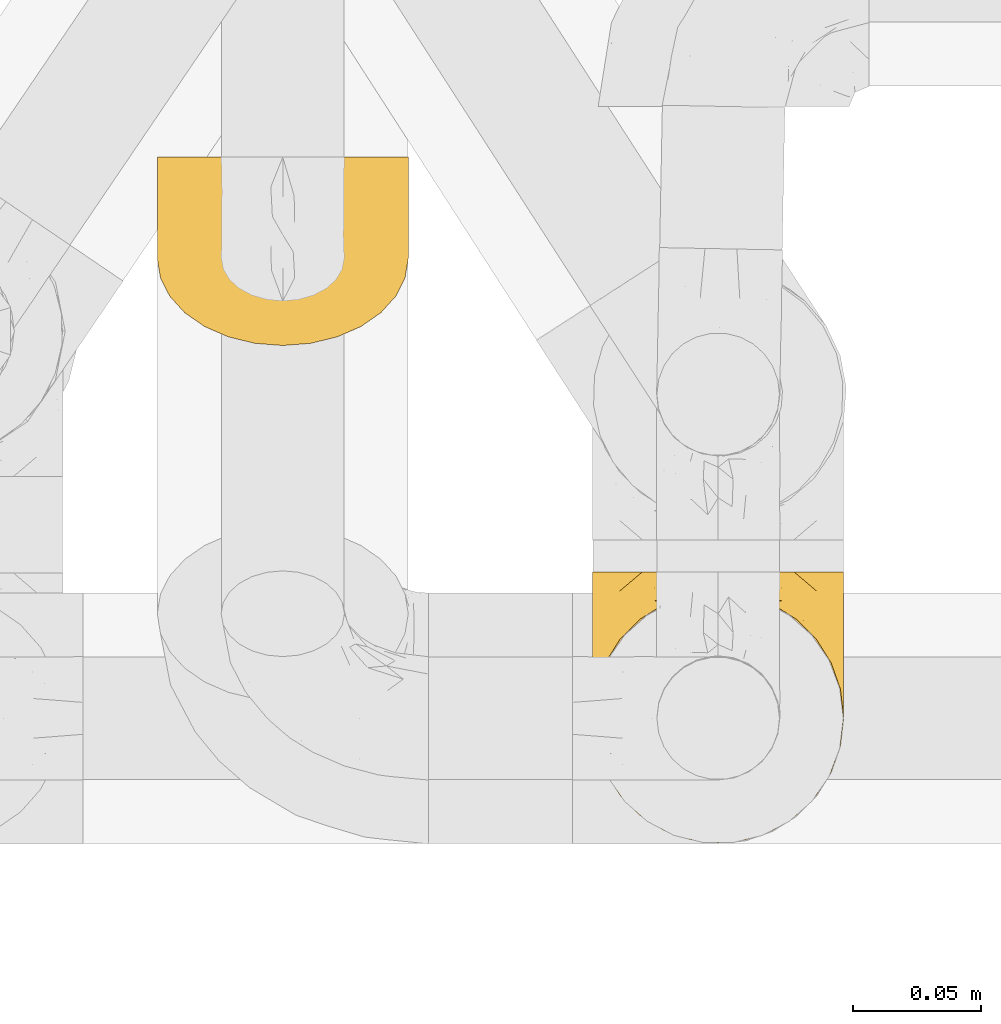
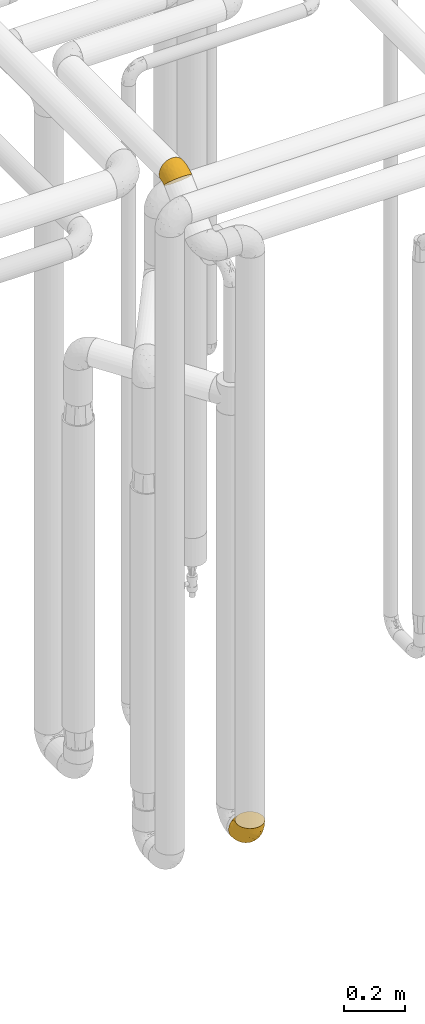
# One storey, part 386 of 827: 2 coverings.
"""IFC2X3 building model written with IfcOpenShell, lengths in millimetres."""

from ifc_helpers import new_model, entity, si_unit, converted_unit, derived_unit, direction, frame, origin, place, context, subcontext, project, spatial, faceted_brep, element, save


model = new_model("IFC2X3")

# Units and contexts
model_context = context("Model", 3, precision=0.01, world=origin(), true_north=direction((6.12303176911189e-17, 1.0)))
body_context = subcontext(model_context, "Body", "Model", "MODEL_VIEW")
ifc_project = project(units=[si_unit("LENGTHUNIT", "METRE", prefix="MILLI"), si_unit("AREAUNIT", "SQUARE_METRE"), si_unit("VOLUMEUNIT", "CUBIC_METRE"), converted_unit("PLANEANGLEUNIT", "DEGREE", entity("IfcRatioMeasure", 0.0174532925199433), si_unit("PLANEANGLEUNIT", "RADIAN"), dimensions=[0, 0, 0, 0, 0, 0, 0]), si_unit("MASSUNIT", "GRAM", prefix="KILO"), derived_unit("MASSDENSITYUNIT", [(si_unit("MASSUNIT", "GRAM", prefix="KILO"), 1), (si_unit("LENGTHUNIT", "METRE"), -3)]), derived_unit("MOMENTOFINERTIAUNIT", [(si_unit("LENGTHUNIT", "METRE"), 4)]), si_unit("TIMEUNIT", "SECOND"), si_unit("FREQUENCYUNIT", "HERTZ"), si_unit("THERMODYNAMICTEMPERATUREUNIT", "DEGREE_CELSIUS"), derived_unit("THERMALTRANSMITTANCEUNIT", [(si_unit("MASSUNIT", "GRAM", prefix="KILO"), 1), (si_unit("THERMODYNAMICTEMPERATUREUNIT", "KELVIN"), -1), (si_unit("TIMEUNIT", "SECOND"), -3)]), derived_unit("VOLUMETRICFLOWRATEUNIT", [(si_unit("LENGTHUNIT", "METRE"), 3), (si_unit("TIMEUNIT", "SECOND"), -1)]), derived_unit("MASSFLOWRATEUNIT", [(si_unit("MASSUNIT", "GRAM", prefix="KILO"), 1), (si_unit("TIMEUNIT", "SECOND"), -1)]), derived_unit("ROTATIONALFREQUENCYUNIT", [(si_unit("TIMEUNIT", "SECOND"), -1)]), si_unit("ELECTRICCURRENTUNIT", "AMPERE"), si_unit("ELECTRICVOLTAGEUNIT", "VOLT"), si_unit("POWERUNIT", "WATT"), si_unit("FORCEUNIT", "NEWTON", prefix="KILO"), si_unit("ILLUMINANCEUNIT", "LUX"), si_unit("LUMINOUSFLUXUNIT", "LUMEN"), si_unit("LUMINOUSINTENSITYUNIT", "CANDELA"), derived_unit("USERDEFINED", [(si_unit("MASSUNIT", "GRAM", prefix="KILO"), -1), (si_unit("LENGTHUNIT", "METRE"), -2), (si_unit("TIMEUNIT", "SECOND"), 3), (si_unit("LUMINOUSFLUXUNIT", "LUMEN"), 1)]), derived_unit("LINEARVELOCITYUNIT", [(si_unit("LENGTHUNIT", "METRE"), 1), (si_unit("TIMEUNIT", "SECOND"), -1)]), si_unit("PRESSUREUNIT", "PASCAL"), derived_unit("USERDEFINED", [(si_unit("LENGTHUNIT", "METRE"), -2), (si_unit("MASSUNIT", "GRAM", prefix="KILO"), 1), (si_unit("TIMEUNIT", "SECOND"), -2)]), derived_unit("LINEARFORCEUNIT", [(si_unit("MASSUNIT", "GRAM", prefix="KILO"), 1), (si_unit("LENGTHUNIT", "METRE"), 1), (si_unit("TIMEUNIT", "SECOND"), -2), (si_unit("LENGTHUNIT", "METRE"), -1)]), derived_unit("PLANARFORCEUNIT", [(si_unit("MASSUNIT", "GRAM", prefix="KILO"), 1), (si_unit("LENGTHUNIT", "METRE"), 1), (si_unit("TIMEUNIT", "SECOND"), -2), (si_unit("LENGTHUNIT", "METRE"), -2)])], contexts=[model_context])

# Site, building, storey
site_placement = place(None, origin())
site = spatial("IfcSite", under=ifc_project, at=site_placement, CompositionType="ELEMENT")
building_placement = place(site_placement, origin())
building = spatial("IfcBuilding", under=site, at=building_placement, CompositionType="ELEMENT")
storey_placement = place(building_placement, frame((0.0, 0.0, 28200.0)))
storey = spatial("IfcBuildingStorey", under=building, at=storey_placement, Name="08", CompositionType="ELEMENT", Elevation=28200.0)

# Coverings
covering_1_placement = place(storey_placement, frame((46777.25, 13781.27, 2947.05)))
element("IfcCovering", 1, at=covering_1_placement, inside=storey, Name=":ADSK_", ObjectType=":ADSK_", PredefinedType="INSULATION", context=body_context, shape_type="Brep", body=[
    faceted_brep([(61.69, 69.06, 2.48), (72.08, 66.53, 5.1), (81.4, 62.46, 9.31), (89.18, 57.05, 14.91), (95.03, 50.57, 21.61), (98.66, 43.35, 29.07), (99.9, 35.76, 36.93), (98.66, 28.15, 44.8), (95.02, 20.93, 52.27), (89.17, 14.45, 58.97), (81.38, 9.04, 64.56), (72.06, 4.98, 68.77), (61.68, 2.45, 71.39), (50.75, 1.6, 72.27), (39.8, 2.45, 71.38), (29.41, 4.98, 68.77), (20.09, 9.05, 64.56), (12.31, 14.46, 58.96), (6.46, 20.94, 52.26), (2.83, 28.16, 44.79), (1.6, 35.76, 36.93), (2.83, 43.36, 29.07), (6.47, 50.58, 21.59), (12.32, 57.06, 14.89), (20.11, 62.47, 9.3), (29.43, 66.54, 5.09), (39.81, 69.06, 2.48), (50.75, 69.92, 1.6), (38.02, 75.37, 5.48), (26.17, 75.37, 10.39), (15.99, 75.37, 18.2), (8.18, 75.37, 28.38), (3.27, 75.37, 40.23), (2.78, 75.37, 43.98), (1.6, 75.37, 52.95), (3.27, 75.37, 65.67), (8.18, 75.37, 77.53), (15.99, 75.37, 87.71), (26.17, 75.37, 95.52), (38.02, 75.37, 100.43), (50.75, 75.37, 102.1), (63.47, 75.37, 100.43), (75.32, 75.37, 95.52), (85.5, 75.37, 87.71), (93.31, 75.37, 77.53), (98.22, 75.37, 65.67), (99.9, 75.37, 52.95), (98.71, 75.37, 43.98), (98.22, 75.37, 40.23), (93.31, 75.37, 28.38), (85.5, 75.37, 18.2), (75.32, 75.37, 10.39), (63.47, 75.37, 5.48), (50.75, 75.37, 3.8), (84.47, 27.34, 75.3), (50.75, 48.48, 98.64), (58.96, 58.66, 100.08), (75.19, 37.47, 88.1), (83.8, 46.12, 84.63), (77.3, 56.48, 92.48), (50.75, 23.34, 88.47), (63.54, 43.26, 95.35), (89.33, 59.62, 81.97), (66.19, 21.25, 84.36), (90.84, 42.68, 74.87), (96.4, 39.77, 62.18), (95.33, 57.71, 71.6), (98.75, 55.84, 60.64), (68.68, 60.14, 97.58), (99.31, 42.12, 51.28), (99.9, 54.01, 48.8), (76.11, 20.02, 78.15), (91.7, 27.99, 65.53), (99.9, 40.39, 39.94), (99.9, 45.03, 42.96), (99.9, 49.52, 45.88), (99.9, 59.26, 49.82), (99.9, 64.52, 50.84), (99.9, 67.24, 51.37), (99.9, 69.95, 51.9), (69.49, 70.82, 6.58), (97.8, 60.98, 36.27), (98.04, 67.74, 38.91), (95.99, 59.44, 30.22), (91.8, 63.88, 23.63), (87.17, 69.77, 19.28), (93.12, 69.11, 27.44), (98.68, 47.33, 32.56), (59.8, 72.32, 4.09), (81.32, 68.15, 13.0), (88.57, 61.45, 17.44), (96.07, 55.44, 28.3), (99.05, 55.09, 39.35), (50.75, 72.43, 3.23), (98.98, 51.04, 36.83), (14.32, 69.77, 19.29), (20.19, 68.16, 12.99), (8.37, 69.11, 27.44), (41.7, 72.32, 4.09), (32.02, 70.82, 6.57), (1.6, 40.39, 39.94), (9.71, 63.89, 23.61), (1.6, 64.52, 50.84), (1.6, 69.95, 51.9), (3.45, 67.74, 38.91), (1.6, 49.52, 45.88), (2.51, 50.99, 36.8), (1.6, 45.03, 42.96), (3.69, 60.97, 36.25), (2.82, 47.34, 32.56), (12.94, 61.45, 17.43), (5.43, 55.45, 28.28), (1.6, 54.01, 48.8), (2.44, 55.06, 39.33), (5.52, 59.45, 30.19), (1.6, 59.26, 49.82), (5.08, 39.77, 62.17), (17.01, 27.35, 75.29), (25.37, 20.02, 78.14), (26.29, 37.48, 88.09), (2.74, 55.84, 60.63), (35.29, 21.26, 84.36), (6.15, 57.72, 71.59), (10.64, 42.69, 74.86), (42.53, 58.66, 100.08), (24.18, 56.49, 92.47), (37.94, 43.27, 95.35), (12.15, 59.61, 81.96), (17.68, 46.12, 84.62), (32.8, 60.13, 97.57), (2.18, 42.12, 51.27), (9.78, 28.0, 65.52)], [[[0, 1, 2, 3, 4, 5, 6, 7, 8, 9, 10, 11, 12, 13, 14, 15, 16, 17, 18, 19, 20, 21, 22, 23, 24, 25, 26, 27]], [[28, 29, 30, 31, 32, 33, 34, 35, 36, 37, 38, 39, 40, 41, 42, 43, 44, 45, 46, 47, 48, 49, 50, 51, 52, 53]], [[9, 54, 10]], [[40, 55, 56]], [[57, 58, 59]], [[55, 60, 61]], [[62, 43, 58]], [[63, 57, 61]], [[58, 54, 64]], [[64, 65, 66]], [[67, 46, 45]], [[66, 65, 67]], [[56, 68, 41]], [[67, 69, 70]], [[57, 54, 58]], [[71, 54, 57]], [[63, 61, 60]], [[60, 12, 63]], [[11, 10, 71]], [[11, 71, 63]], [[43, 59, 58]], [[13, 12, 60]], [[72, 54, 9]], [[59, 43, 42]], [[57, 59, 68]], [[69, 6, 73, 74, 75, 70]], [[8, 7, 65]], [[72, 65, 64]], [[63, 71, 57]], [[54, 71, 10]], [[8, 72, 9]], [[56, 55, 61]], [[62, 58, 64]], [[11, 63, 12]], [[42, 41, 68]], [[66, 44, 62]], [[7, 69, 65]], [[45, 44, 66]], [[67, 70, 76, 77, 78, 79, 46]], [[45, 66, 67]], [[66, 62, 64]], [[43, 62, 44]], [[65, 72, 8]], [[54, 72, 64]], [[65, 69, 67]], [[6, 69, 7]], [[61, 57, 68]], [[40, 56, 41]], [[61, 68, 56]], [[42, 68, 59]], [[51, 80, 52]], [[81, 82, 76]], [[83, 84, 81]], [[84, 85, 86]], [[48, 78, 82]], [[85, 51, 50]], [[4, 87, 5]], [[88, 0, 27]], [[89, 1, 80]], [[53, 52, 88]], [[51, 89, 80]], [[86, 50, 49]], [[85, 50, 86]], [[81, 86, 82]], [[90, 91, 3]], [[4, 3, 91]], [[91, 83, 92]], [[6, 5, 73]], [[81, 84, 86]], [[82, 86, 49]], [[48, 47, 46, 79, 78]], [[93, 88, 27]], [[92, 94, 91]], [[1, 0, 80]], [[2, 1, 89]], [[87, 73, 5]], [[0, 88, 80]], [[90, 89, 84]], [[48, 82, 49]], [[2, 90, 3]], [[70, 81, 76]], [[53, 88, 93]], [[89, 90, 2]], [[90, 84, 83]], [[82, 78, 77, 76]], [[84, 89, 85]], [[51, 85, 89]], [[91, 87, 4]], [[73, 87, 74]], [[81, 92, 83]], [[87, 94, 74]], [[80, 88, 52]], [[81, 70, 92]], [[90, 83, 91]], [[70, 75, 92]], [[92, 75, 94]], [[74, 94, 75]], [[87, 91, 94]], [[95, 29, 96]], [[30, 97, 31]], [[98, 99, 28]], [[21, 20, 100]], [[95, 101, 97]], [[99, 29, 28]], [[32, 102, 103, 34, 33]], [[29, 95, 30]], [[104, 31, 97]], [[95, 97, 30]], [[105, 106, 107]], [[25, 96, 99]], [[53, 93, 98]], [[32, 104, 102]], [[27, 26, 98]], [[101, 108, 97]], [[99, 26, 25]], [[100, 107, 109]], [[104, 32, 31]], [[24, 96, 25]], [[23, 110, 24]], [[111, 23, 22]], [[110, 96, 24]], [[109, 111, 22]], [[112, 108, 113]], [[21, 109, 22]], [[29, 99, 96]], [[111, 114, 110]], [[108, 115, 104]], [[93, 27, 98]], [[108, 104, 97]], [[114, 108, 101]], [[111, 110, 23]], [[96, 110, 101]], [[115, 108, 112]], [[115, 102, 104]], [[96, 101, 95]], [[100, 109, 21]], [[113, 108, 114]], [[105, 113, 106]], [[99, 98, 26]], [[53, 98, 28]], [[110, 114, 101]], [[111, 106, 113]], [[111, 113, 114]], [[105, 112, 113]], [[111, 109, 106]], [[107, 106, 109]], [[19, 18, 116]], [[117, 118, 119]], [[120, 34, 103, 102, 115, 112]], [[117, 17, 16]], [[121, 118, 15]], [[122, 116, 123]], [[39, 124, 40]], [[37, 125, 38]], [[121, 126, 119]], [[127, 37, 36]], [[123, 128, 127]], [[124, 129, 126]], [[129, 119, 126]], [[125, 37, 128]], [[120, 130, 116]], [[125, 128, 119]], [[116, 18, 131]], [[55, 124, 126]], [[131, 18, 17]], [[123, 127, 122]], [[122, 120, 116]], [[123, 131, 117]], [[126, 121, 60]], [[118, 16, 15]], [[14, 13, 60]], [[126, 60, 55]], [[14, 60, 121]], [[118, 121, 119]], [[118, 117, 16]], [[14, 121, 15]], [[128, 117, 119]], [[130, 20, 19]], [[129, 38, 125]], [[123, 117, 128]], [[36, 35, 122]], [[120, 112, 130]], [[122, 35, 120]], [[34, 120, 35]], [[37, 127, 128]], [[122, 127, 36]], [[117, 131, 17]], [[116, 131, 123]], [[130, 112, 105, 107, 100, 20]], [[116, 130, 19]], [[40, 124, 55]], [[129, 124, 39]], [[38, 129, 39]], [[129, 125, 119]]]),
])
covering_2_placement = place(storey_placement, frame((46947.78, 13586.48, 349.25)))
element("IfcCovering", 2, at=covering_2_placement, inside=storey, Name=":ADSK_", ObjectType=":ADSK_", PredefinedType="INSULATION", context=body_context, shape_type="Brep", body=[
    faceted_brep([(2.83, 39.8, 107.73), (6.47, 29.41, 107.73), (12.32, 20.09, 107.73), (20.11, 12.31, 107.73), (29.43, 6.46, 107.73), (39.81, 2.83, 107.73), (50.75, 1.6, 107.73), (61.69, 2.83, 107.73), (72.08, 6.47, 107.73), (81.4, 12.32, 107.73), (89.18, 20.11, 107.73), (95.03, 29.43, 107.73), (98.66, 39.81, 107.73), (99.9, 50.75, 107.74), (99.25, 56.45, 107.74), (98.66, 61.69, 107.74), (96.84, 66.88, 107.74), (95.02, 72.08, 107.74), (89.17, 81.4, 107.74), (81.38, 89.18, 107.74), (72.06, 95.03, 107.74), (61.68, 98.66, 107.74), (50.75, 99.9, 107.74), (39.8, 98.66, 107.74), (29.41, 95.02, 107.74), (20.09, 89.17, 107.74), (12.31, 81.38, 107.74), (6.46, 72.06, 107.74), (4.64, 66.87, 107.74), (2.83, 61.68, 107.74), (2.24, 56.45, 107.74), (1.92, 53.6, 107.74), (1.6, 50.75, 107.74), (63.47, 107.75, 98.22), (75.32, 107.75, 93.31), (80.41, 107.75, 89.4), (85.5, 107.75, 85.5), (89.4, 107.75, 80.41), (93.31, 107.75, 75.32), (95.77, 107.75, 69.39), (98.22, 107.75, 63.47), (99.14, 107.75, 56.48), (99.52, 107.75, 53.61), (99.9, 107.75, 50.75), (98.22, 107.75, 38.02), (93.31, 107.75, 26.17), (85.5, 107.75, 15.99), (75.32, 107.75, 8.18), (63.47, 107.75, 3.27), (50.75, 107.75, 1.6), (38.02, 107.75, 3.27), (26.17, 107.75, 8.18), (15.99, 107.75, 15.99), (8.18, 107.75, 26.17), (3.27, 107.75, 38.02), (1.6, 107.75, 50.75), (2.35, 107.75, 56.48), (3.27, 107.75, 63.47), (5.73, 107.75, 69.39), (8.18, 107.75, 75.32), (12.09, 107.75, 80.41), (15.99, 107.75, 85.5), (21.08, 107.75, 89.4), (26.17, 107.75, 93.31), (38.02, 107.75, 98.22), (50.75, 107.75, 99.9), (42.19, 39.39, 27.52), (28.41, 49.76, 25.31), (37.77, 57.39, 16.29), (50.75, 74.95, 6.79), (42.85, 85.97, 4.51), (50.75, 95.66, 3.51), (24.75, 67.82, 17.47), (33.81, 83.09, 7.6), (22.57, 89.16, 12.27), (7.18, 37.02, 70.89), (2.73, 43.46, 87.16), (3.09, 51.79, 67.3), (6.92, 85.58, 31.65), (11.58, 62.84, 33.58), (5.17, 62.78, 47.23), (2.71, 88.17, 43.26), (1.6, 85.93, 55.08), (1.6, 91.42, 53.99), (1.6, 96.91, 52.9), (1.6, 99.62, 52.36), (1.6, 102.33, 51.82), (14.18, 82.57, 21.5), (5.88, 32.76, 89.92), (41.06, 13.8, 60.43), (36.25, 6.77, 82.98), (28.62, 16.46, 64.78), (1.6, 55.09, 85.93), (1.6, 58.18, 81.3), (1.6, 61.27, 76.68), (1.6, 64.35, 72.06), (1.6, 67.44, 67.44), (10.85, 24.18, 88.72), (38.35, 23.38, 45.97), (9.6, 49.77, 47.13), (26.24, 9.85, 89.38), (50.75, 3.51, 95.64), (19.31, 55.76, 28.49), (16.4, 42.35, 42.81), (24.56, 37.78, 38.28), (50.75, 21.87, 45.34), (50.75, 33.62, 33.6), (18.47, 17.11, 82.56), (1.6, 51.28, 105.03), (1.6, 51.82, 102.32), (1.6, 52.9, 96.9), (1.6, 53.99, 91.41), (14.36, 28.02, 65.9), (20.65, 28.98, 53.12), (2.32, 69.9, 54.37), (50.75, 6.79, 74.93), (1.6, 72.07, 64.35), (1.6, 76.69, 61.26), (1.6, 81.31, 58.17), (50.75, 45.36, 21.86), (33.89, 34.8, 34.79), (29.25, 25.72, 48.47), (50.75, 14.33, 60.14), (50.75, 60.15, 14.33), (2.8, 62.38, 99.07), (2.48, 100.57, 60.55), (2.7, 91.06, 64.18), (3.2, 97.66, 64.36), (17.38, 88.57, 99.41), (30.43, 96.22, 103.61), (2.95, 66.85, 87.74), (2.19, 61.94, 89.37), (17.92, 101.4, 88.34), (12.02, 100.07, 82.14), (25.73, 101.36, 94.51), (16.64, 95.95, 89.64), (25.61, 96.31, 98.41), (36.72, 101.98, 99.71), (10.66, 85.88, 89.36), (6.87, 78.89, 88.21), (11.12, 82.81, 95.2), (10.31, 102.58, 79.14), (5.94, 96.59, 72.69), (12.85, 82.88, 101.22), (9.75, 88.68, 84.73), (4.63, 69.09, 97.47), (50.75, 102.19, 102.19), (38.56, 99.48, 103.3), (3.12, 70.56, 82.65), (17.58, 91.08, 95.42), (3.97, 77.57, 78.66), (2.73, 86.38, 66.45), (6.23, 91.79, 75.3), (3.45, 81.71, 72.74), (10.84, 94.11, 82.93), (7.98, 76.09, 99.26), (7.33, 76.91, 93.5), (2.39, 81.45, 67.35), (75.76, 101.37, 94.51), (90.65, 94.13, 82.94), (83.57, 101.41, 88.33), (84.84, 95.97, 89.63), (71.05, 96.22, 103.61), (98.54, 66.85, 87.74), (99.3, 61.94, 89.38), (99.9, 58.18, 81.3), (96.86, 69.1, 97.47), (84.1, 88.58, 99.41), (99.9, 96.91, 52.9), (99.9, 102.33, 51.82), (99.9, 105.04, 51.28), (88.63, 82.91, 101.21), (90.36, 82.82, 95.19), (98.29, 97.66, 64.36), (95.55, 96.59, 72.69), (89.48, 100.07, 82.13), (95.26, 91.79, 75.3), (91.18, 102.58, 79.14), (93.48, 76.13, 99.28), (94.15, 76.93, 93.51), (99.01, 100.57, 60.55), (98.76, 86.38, 66.45), (98.85, 90.86, 63.96), (99.9, 52.9, 96.9), (98.69, 62.39, 99.06), (64.78, 101.98, 99.7), (99.9, 91.42, 53.99), (99.9, 85.93, 55.08), (62.91, 99.49, 103.29), (99.9, 51.82, 102.32), (99.9, 52.36, 99.61), (99.9, 61.27, 76.68), (98.37, 70.56, 82.66), (83.9, 91.09, 95.42), (99.9, 64.35, 72.06), (97.5, 77.63, 78.69), (94.62, 78.89, 88.19), (98.04, 81.71, 72.75), (91.72, 88.7, 84.75), (99.9, 53.99, 91.41), (99.9, 55.09, 85.93), (75.87, 96.32, 98.41), (90.82, 85.9, 89.36), (99.1, 81.45, 67.35), (99.9, 76.69, 61.26), (99.9, 81.31, 58.17), (99.9, 72.07, 64.35), (99.9, 67.44, 67.44), (99.09, 69.61, 54.08), (58.64, 85.97, 4.51), (87.31, 82.57, 21.5), (89.93, 63.16, 33.43), (82.22, 55.81, 28.49), (76.74, 67.81, 17.47), (73.12, 49.73, 25.36), (95.54, 32.55, 90.17), (98.7, 43.23, 86.96), (98.79, 88.17, 43.26), (63.72, 57.38, 16.29), (67.68, 83.08, 7.6), (78.92, 89.16, 12.27), (94.57, 85.58, 31.65), (72.88, 16.47, 64.78), (65.25, 6.78, 82.98), (60.45, 13.81, 60.43), (76.94, 37.71, 38.36), (67.61, 34.8, 34.79), (94.38, 36.83, 71.53), (59.31, 39.39, 27.52), (83.03, 17.12, 82.56), (90.66, 24.2, 88.72), (80.8, 28.88, 53.19), (72.21, 25.7, 48.48), (98.39, 51.77, 67.27), (92.31, 45.66, 52.31), (63.1, 23.4, 45.93), (75.27, 9.86, 89.38), (87.15, 28.12, 65.74), (96.03, 62.28, 46.73), (85.1, 42.36, 42.81)], [[[0, 1, 2, 3, 4, 5, 6, 7, 8, 9, 10, 11, 12, 13, 14, 15, 16, 17, 18, 19, 20, 21, 22, 23, 24, 25, 26, 27, 28, 29, 30, 31, 32]], [[33, 34, 35, 36, 37, 38, 39, 40, 41, 42, 43, 44, 45, 46, 47, 48, 49, 50, 51, 52, 53, 54, 55, 56, 57, 58, 59, 60, 61, 62, 63, 64, 65]], [[66, 67, 68]], [[69, 70, 71]], [[68, 72, 73]], [[73, 72, 74]], [[75, 76, 77]], [[78, 79, 80]], [[51, 50, 73]], [[81, 82, 83, 84, 85, 86, 55]], [[52, 87, 53]], [[74, 52, 51]], [[1, 0, 88]], [[89, 90, 91]], [[77, 92, 93, 94, 95, 96]], [[55, 54, 81]], [[78, 53, 87]], [[4, 90, 5]], [[88, 76, 75]], [[97, 2, 1]], [[89, 91, 98]], [[99, 80, 79]], [[90, 4, 100]], [[74, 87, 52]], [[100, 4, 3]], [[90, 101, 5]], [[79, 102, 103]], [[102, 67, 104]], [[105, 98, 106]], [[107, 3, 2]], [[76, 32, 108, 109, 110, 111, 92]], [[107, 112, 113]], [[114, 77, 96]], [[89, 115, 90]], [[114, 96, 116, 117, 118, 82]], [[75, 97, 88]], [[119, 66, 68]], [[50, 71, 70]], [[100, 91, 90]], [[99, 77, 80]], [[102, 104, 103]], [[97, 107, 2]], [[80, 81, 78]], [[107, 97, 112]], [[68, 73, 70]], [[66, 98, 120]], [[78, 81, 54]], [[114, 81, 80]], [[53, 78, 54]], [[78, 87, 79]], [[102, 87, 72]], [[79, 103, 99]], [[3, 107, 100]], [[91, 100, 107]], [[88, 97, 1]], [[112, 97, 75]], [[99, 112, 75]], [[103, 104, 113]], [[91, 121, 98]], [[89, 105, 122, 115]], [[101, 90, 115]], [[101, 6, 5]], [[88, 0, 76]], [[32, 76, 0]], [[92, 77, 76]], [[73, 74, 51]], [[87, 74, 72]], [[81, 114, 82]], [[77, 114, 80]], [[87, 102, 79]], [[67, 102, 72]], [[68, 67, 72]], [[67, 120, 104]], [[120, 121, 104]], [[104, 121, 113]], [[121, 120, 98]], [[91, 107, 113]], [[91, 113, 121]], [[103, 113, 112]], [[66, 119, 106]], [[105, 89, 98]], [[68, 69, 123, 119]], [[98, 66, 106]], [[66, 120, 67]], [[50, 49, 71]], [[50, 70, 73]], [[112, 99, 103]], [[77, 99, 75]], [[69, 68, 70]], [[28, 124, 110]], [[84, 83, 125]], [[126, 82, 118]], [[59, 58, 127]], [[128, 24, 129]], [[130, 93, 131]], [[132, 62, 133]], [[134, 135, 136]], [[137, 65, 64]], [[64, 134, 137]], [[138, 139, 140]], [[111, 110, 124, 92]], [[134, 136, 137]], [[134, 64, 63]], [[141, 60, 142]], [[125, 58, 57]], [[143, 128, 140]], [[143, 25, 128]], [[127, 83, 82]], [[27, 124, 28]], [[31, 30, 29, 110, 109, 108, 32]], [[29, 28, 110]], [[135, 144, 138]], [[27, 145, 124]], [[57, 56, 55, 86, 85, 84]], [[146, 147, 22]], [[147, 137, 136]], [[24, 128, 25]], [[95, 94, 148]], [[24, 23, 129]], [[149, 138, 128]], [[124, 145, 131]], [[127, 58, 125]], [[150, 148, 139]], [[127, 126, 142]], [[142, 59, 127]], [[151, 142, 126]], [[152, 153, 154]], [[152, 133, 141]], [[145, 27, 26]], [[143, 155, 26]], [[156, 148, 130]], [[61, 133, 62]], [[134, 132, 135]], [[136, 129, 147]], [[65, 137, 146]], [[157, 151, 117]], [[151, 118, 117]], [[152, 142, 151]], [[157, 116, 153]], [[144, 150, 138]], [[152, 151, 157]], [[133, 152, 154]], [[133, 154, 132]], [[152, 141, 142]], [[135, 132, 154]], [[134, 63, 132]], [[144, 135, 154]], [[135, 138, 149]], [[154, 153, 144]], [[150, 153, 96]], [[153, 150, 144]], [[148, 94, 130]], [[82, 126, 127]], [[118, 151, 126]], [[150, 96, 95]], [[139, 148, 156]], [[150, 95, 148]], [[93, 92, 131]], [[130, 145, 155]], [[130, 94, 93]], [[129, 23, 147]], [[129, 136, 149]], [[22, 147, 23]], [[146, 137, 147]], [[84, 125, 57]], [[127, 125, 83]], [[140, 139, 156]], [[150, 139, 138]], [[140, 156, 143]], [[138, 140, 128]], [[155, 143, 156]], [[26, 25, 143]], [[130, 155, 156]], [[145, 26, 155]], [[132, 63, 62]], [[124, 131, 92]], [[130, 131, 145]], [[129, 149, 128]], [[135, 149, 136]], [[60, 141, 61]], [[60, 59, 142]], [[133, 61, 141]], [[116, 96, 153]], [[152, 157, 153]], [[157, 117, 116]], [[34, 33, 158]], [[159, 160, 161]], [[21, 20, 162]], [[163, 164, 165]], [[18, 17, 166]], [[167, 20, 19]], [[42, 41, 40, 168, 169, 170, 43]], [[171, 172, 167]], [[173, 38, 174]], [[175, 176, 177]], [[178, 163, 179]], [[40, 180, 168]], [[181, 182, 174]], [[16, 183, 184]], [[65, 146, 185]], [[186, 173, 187]], [[22, 21, 188]], [[173, 39, 38]], [[14, 13, 189, 190, 183, 15]], [[180, 40, 39]], [[191, 192, 163]], [[193, 162, 167]], [[33, 185, 158]], [[179, 172, 171]], [[194, 195, 192]], [[17, 184, 166]], [[172, 179, 196]], [[197, 198, 195]], [[199, 200, 184, 183]], [[183, 16, 15]], [[17, 16, 184]], [[201, 158, 185]], [[193, 167, 202]], [[188, 162, 201]], [[203, 204, 181]], [[186, 180, 173]], [[159, 176, 175]], [[205, 182, 181]], [[205, 181, 204]], [[200, 164, 184]], [[164, 163, 166]], [[171, 178, 179]], [[201, 193, 161]], [[175, 160, 159]], [[65, 185, 33]], [[162, 188, 21]], [[174, 176, 181]], [[173, 182, 187]], [[176, 197, 203]], [[198, 159, 161]], [[197, 206, 203]], [[174, 38, 37]], [[197, 176, 159]], [[177, 176, 174]], [[175, 35, 160]], [[34, 158, 160]], [[161, 160, 158]], [[201, 161, 158]], [[198, 161, 202]], [[195, 198, 202]], [[197, 159, 198]], [[192, 196, 179]], [[207, 197, 195]], [[187, 182, 205]], [[174, 182, 173]], [[192, 191, 194]], [[194, 207, 195]], [[196, 195, 202]], [[179, 163, 192]], [[167, 162, 20]], [[165, 164, 200]], [[165, 191, 163]], [[188, 201, 185]], [[185, 146, 188]], [[22, 188, 146]], [[173, 180, 39]], [[168, 180, 186]], [[195, 196, 192]], [[172, 202, 167]], [[202, 172, 196]], [[171, 167, 19]], [[19, 18, 171]], [[178, 171, 18]], [[18, 166, 178]], [[163, 178, 166]], [[35, 175, 36]], [[35, 34, 160]], [[184, 164, 166]], [[161, 193, 202]], [[162, 193, 201]], [[175, 177, 36]], [[37, 36, 177]], [[174, 37, 177]], [[176, 203, 181]], [[206, 197, 207]], [[206, 204, 203]], [[208, 187, 205, 204, 206, 207]], [[48, 209, 71]], [[210, 211, 212]], [[213, 212, 214]], [[215, 216, 12]], [[217, 43, 170, 169, 168, 186, 187]], [[218, 219, 213]], [[47, 46, 220]], [[209, 48, 219]], [[210, 221, 211]], [[221, 45, 44]], [[220, 219, 47]], [[47, 219, 48]], [[220, 210, 213]], [[222, 223, 224]], [[210, 46, 45]], [[225, 226, 214]], [[43, 217, 44]], [[216, 215, 227]], [[218, 214, 228]], [[13, 12, 216]], [[223, 8, 7]], [[9, 229, 10]], [[10, 230, 11]], [[231, 222, 232]], [[233, 207, 194, 191, 165, 200]], [[234, 233, 227]], [[221, 44, 217]], [[106, 228, 235]], [[223, 236, 8]], [[230, 237, 227]], [[8, 236, 9]], [[115, 223, 101]], [[238, 233, 234]], [[230, 10, 229]], [[222, 229, 236]], [[223, 7, 101]], [[222, 235, 232]], [[224, 115, 122, 105]], [[215, 11, 230]], [[208, 233, 238]], [[209, 218, 69]], [[218, 213, 214]], [[228, 119, 218]], [[208, 217, 187]], [[238, 211, 221]], [[238, 221, 217]], [[45, 221, 210]], [[234, 211, 238]], [[212, 211, 239]], [[222, 236, 223]], [[229, 9, 236]], [[237, 230, 229]], [[215, 230, 227]], [[231, 229, 222]], [[234, 237, 239]], [[115, 224, 223]], [[232, 235, 226]], [[7, 6, 101]], [[233, 208, 207]], [[217, 208, 238]], [[216, 227, 233]], [[12, 11, 215]], [[233, 200, 216]], [[216, 200, 199, 183, 190, 189, 13]], [[210, 220, 46]], [[219, 220, 213]], [[71, 209, 69]], [[71, 49, 48]], [[218, 209, 219]], [[225, 214, 212]], [[210, 212, 213]], [[225, 212, 239]], [[214, 226, 228]], [[231, 239, 237]], [[232, 226, 225]], [[231, 232, 225]], [[235, 222, 224]], [[239, 231, 225]], [[231, 237, 229]], [[224, 105, 235]], [[235, 105, 106]], [[235, 228, 226]], [[123, 69, 218, 119]], [[106, 119, 228]], [[237, 234, 227]], [[211, 234, 239]]]),
])

save(model, "model.ifc")
